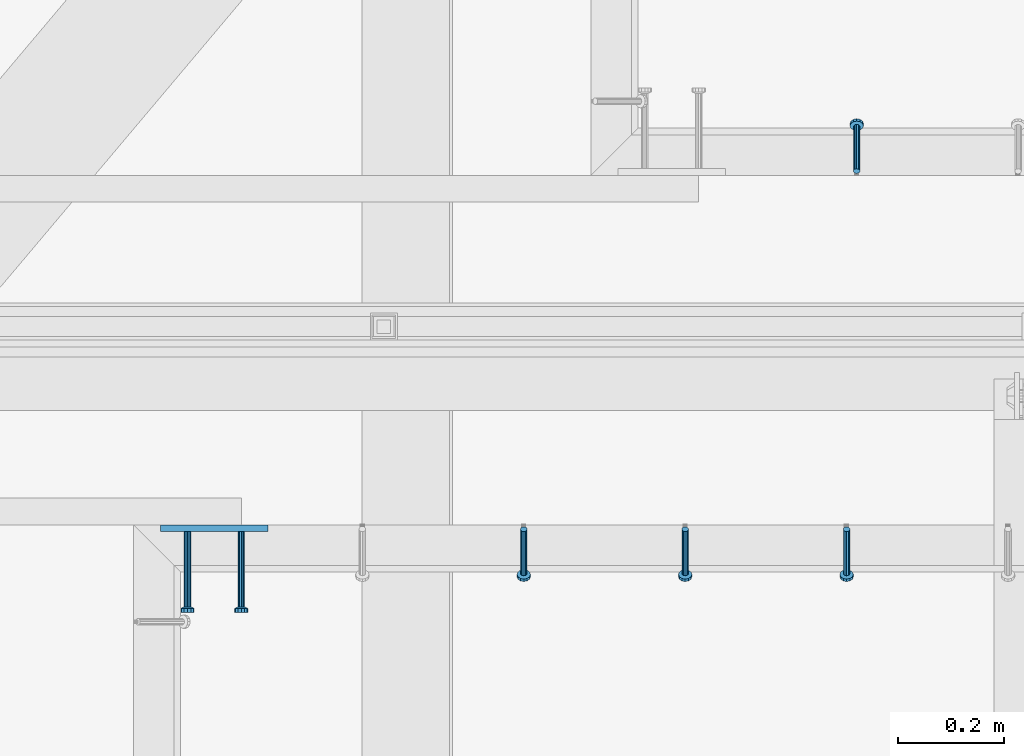
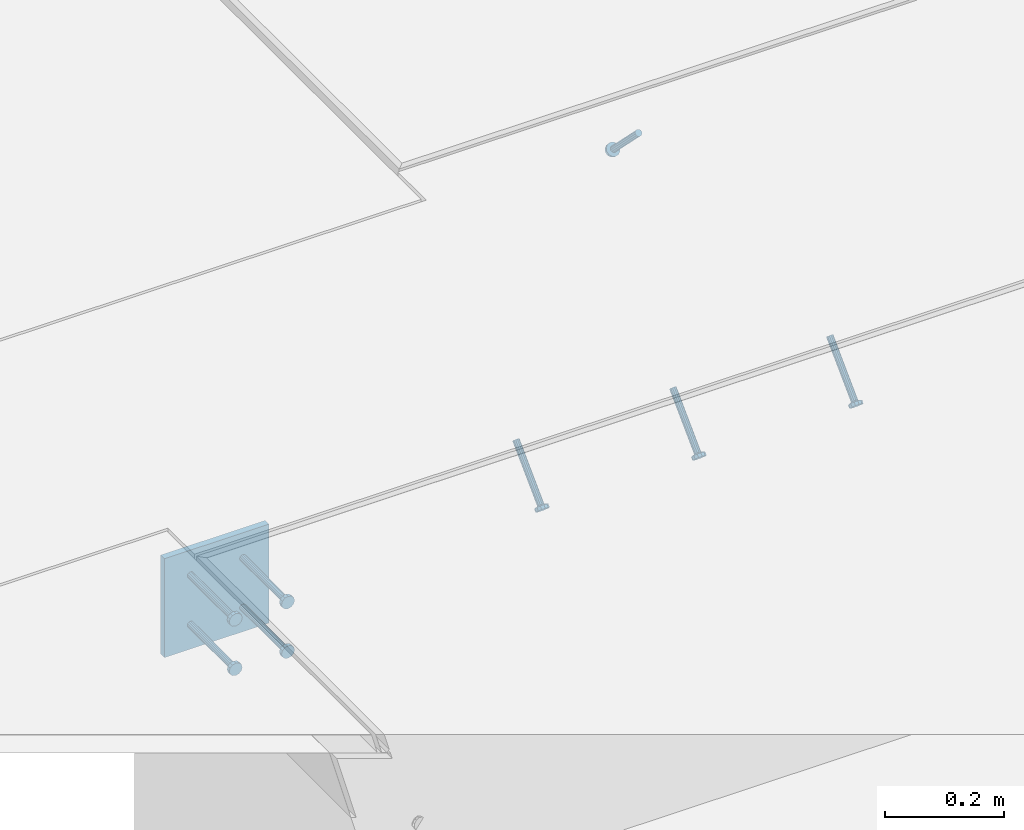
# One storey, part 2123 of 3843: 5 beams, 4 members, 3 elements without a shape of their own.
"""IFC2X3 building model written with IfcOpenShell, lengths in millimetres."""

from ifc_helpers import new_model, si_unit, frame, origin_with_axes, place, context, subcontext, project, spatial, faceted_brep, material, type_object, element, aggregate, save


model = new_model("IFC2X3")

# Units and contexts
model_context = context("Model", 3, precision=1e-05, world=origin_with_axes())
body_context = subcontext(model_context, "Body", "Model", "MODEL_VIEW")
ifc_project = project(units=[si_unit("LENGTHUNIT", "METRE", prefix="MILLI"), si_unit("AREAUNIT", "SQUARE_METRE"), si_unit("VOLUMEUNIT", "CUBIC_METRE"), si_unit("MASSUNIT", "GRAM", prefix="KILO"), si_unit("TIMEUNIT", "SECOND"), si_unit("PLANEANGLEUNIT", "RADIAN"), si_unit("SOLIDANGLEUNIT", "STERADIAN"), si_unit("THERMODYNAMICTEMPERATUREUNIT", "DEGREE_CELSIUS"), si_unit("LUMINOUSINTENSITYUNIT", "LUMEN")], contexts=[model_context])

# Site, building, storey
site_placement = place(None, origin_with_axes())
site = spatial("IfcSite", under=ifc_project, at=site_placement, CompositionType="ELEMENT")
building_placement = place(site_placement, origin_with_axes())
building = spatial("IfcBuilding", under=site, at=building_placement, Name="Undefined", CompositionType="ELEMENT")
storey_placement = place(building_placement, origin_with_axes())
storey = spatial("IfcBuildingStorey", under=building, at=storey_placement, Name="Undefined", CompositionType="ELEMENT", Elevation=0.0)

# Assembly, member
assembly_1_placement = place(storey_placement, origin_with_axes())
assembly_1 = element("IfcElementAssembly", 1, at=assembly_1_placement, inside=storey, Name="EMBED_ANGLE", AssemblyPlace="NOTDEFINED", PredefinedType="RIGID_FRAME")
ifc_material_1 = material(Name="STEEL/A108")
member_type = type_object("IfcMemberType", PredefinedType="NOTDEFINED")
member_1_placement = place(assembly_1_placement, frame((53309.0118945312, 28836.9375, 30446.6625), z_axis=(-1.0, 0.0, 0.0), x_axis=(5.70000238222118e-08, 0.707106781186546, -0.707106781186546)))
member_1 = element("IfcMember", 2, at=member_1_placement, type_object=member_type, material=ifc_material_1, Name="HEADED STUD ANCHOR", context=body_context, shape_type="Brep", body=[
    faceted_brep([(7.27595761418343e-12, -3.18000006675175, 5.5), (0.0, -5.49999999998363, 3.1800000667572), (118.110000000976, -5.49999999999091, 3.1800000667572), (118.110000000983, -3.18000006675175, 5.5), (0.0, -6.3499999046162, 0.0), (118.110000000968, -6.34999990461256, 0.0), (0.0, -5.49999999998363, -3.1800000667572), (118.110000000976, -5.49999999999091, -3.1800000667572), (7.27595761418343e-12, -3.18000006675175, -5.5), (118.110000000983, -3.18000006675175, -5.5), (7.27595761418343e-12, -1.81898940354586e-12, -6.34999990463257), (118.110000000968, -1.81898940354586e-12, -6.34999990463257), (0.0, 3.18000006675175, -5.5), (118.110000000968, 3.18000006674811, -5.5), (7.27595761418343e-12, 5.49999999998363, -3.1800000667572), (118.110000000983, 5.49999999998363, -3.1800000667572), (7.27595761418343e-12, 6.3499999046162, 0.0), (118.110000000976, 6.34999990461256, 0.0), (7.27595761418343e-12, 5.49999999998363, 3.1800000667572), (118.110000000983, 5.49999999998363, 3.1800000667572), (0.0, 3.18000006675175, 5.5), (118.110000000968, 3.18000006674811, 5.5), (7.27595761418343e-12, -1.81898940354586e-12, 6.34999990463257), (118.110000000968, -1.81898940354586e-12, 6.34999990463257), (120.650000000991, -10.9899997710909, 6.34999990463257), (120.650000000998, -6.34000015257152, 10.9899997711182), (120.650000000991, -12.6999998092379, 0.0), (120.650000000991, -10.9899997710909, -6.34999990463257), (120.650000000998, -6.34000015257152, -10.9899997711182), (120.650000000991, -1.81898940354586e-12, -12.6899995803833), (120.650000000991, 6.34000015257152, -10.9899997711182), (120.650000000998, 10.9899997710909, -6.34999990463257), (120.650000000991, 12.6999998092342, 0.0), (120.650000000998, 10.9899997710909, 6.34999990463257), (120.650000000991, 6.34000015257152, 10.9899997711182), (120.650000000991, -1.81898940354586e-12, 12.6899995803833), (127.000000001048, -10.9899997710945, 6.34999990463257), (127.000000001048, -6.34000015257152, 10.9899997711182), (127.000000001048, -12.6999998092342, 0.0), (127.000000001048, -10.9899997710945, -6.34999990463257), (127.000000001048, -6.34000015257152, -10.9899997711182), (127.000000001048, 1.81898940354586e-12, -12.6899995803833), (127.000000001048, 6.34000015256788, -10.9899997711182), (127.000000001048, 10.9899997710909, -6.34999990463257), (127.000000001048, 12.6999998092379, 0.0), (127.000000001048, 10.9899997710909, 6.34999990463257), (127.000000001048, 6.34000015256788, 10.9899997711182), (127.000000001048, 1.81898940354586e-12, 12.6899995803833)], [[[0, 1, 2, 3]], [[1, 4, 5, 2]], [[4, 6, 7, 5]], [[6, 8, 9, 7]], [[8, 10, 11, 9]], [[10, 12, 13, 11]], [[12, 14, 15, 13]], [[14, 16, 17, 15]], [[16, 18, 19, 17]], [[18, 20, 21, 19]], [[20, 22, 23, 21]], [[22, 0, 3, 23]], [[22, 20, 18, 16, 14, 12, 10, 8, 6, 4, 1, 0]], [[3, 2, 24, 25]], [[2, 5, 26, 24]], [[5, 7, 27, 26]], [[7, 9, 28, 27]], [[9, 11, 29, 28]], [[11, 13, 30, 29]], [[13, 15, 31, 30]], [[15, 17, 32, 31]], [[17, 19, 33, 32]], [[19, 21, 34, 33]], [[21, 23, 35, 34]], [[23, 3, 25, 35]], [[25, 24, 36, 37]], [[24, 26, 38, 36]], [[26, 27, 39, 38]], [[27, 28, 40, 39]], [[28, 29, 41, 40]], [[29, 30, 42, 41]], [[30, 31, 43, 42]], [[31, 32, 44, 43]], [[32, 33, 45, 44]], [[33, 34, 46, 45]], [[34, 35, 47, 46]], [[35, 25, 37, 47]], [[38, 39, 40, 41, 42, 43, 44, 45, 46, 47, 37, 36]]]),
])
aggregate(assembly_1, [member_1])

# Assembly, members
assembly_2_placement = place(storey_placement, origin_with_axes())
assembly_2 = element("IfcElementAssembly", 3, at=assembly_2_placement, inside=storey, Name="EMBED_ANGLE", AssemblyPlace="NOTDEFINED", PredefinedType="RIGID_FRAME")
member_2_placement = place(assembly_2_placement, frame((53289.9623417968, 28160.6624984764, 30446.6625), z_axis=(-1.0, 0.0, 0.0), x_axis=(0.0, -0.707106781186548, -0.707106781186548)))
member_2 = element("IfcMember", 4, at=member_2_placement, type_object=member_type, material=ifc_material_1, Name="HEADED STUD ANCHOR", context=body_context, shape_type="Brep", body=[
    faceted_brep([(7.27595761418343e-12, -3.18000006675175, 5.5), (0.0, -5.49999999998363, 3.1800000667572), (118.110000000976, -5.49999999999091, 3.1800000667572), (118.110000000983, -3.18000006675175, 5.5), (0.0, -6.3499999046162, 0.0), (118.110000000968, -6.34999990461256, 0.0), (0.0, -5.49999999998363, -3.1800000667572), (118.110000000976, -5.49999999999091, -3.1800000667572), (7.27595761418343e-12, -3.18000006675175, -5.5), (118.110000000983, -3.18000006675175, -5.5), (7.27595761418343e-12, -1.81898940354586e-12, -6.34999990463257), (118.110000000968, -1.81898940354586e-12, -6.34999990463257), (0.0, 3.18000006675175, -5.5), (118.110000000968, 3.18000006674811, -5.5), (7.27595761418343e-12, 5.49999999998363, -3.1800000667572), (118.110000000983, 5.49999999998363, -3.1800000667572), (7.27595761418343e-12, 6.3499999046162, 0.0), (118.110000000976, 6.34999990461256, 0.0), (7.27595761418343e-12, 5.49999999998363, 3.1800000667572), (118.110000000983, 5.49999999998363, 3.1800000667572), (0.0, 3.18000006675175, 5.5), (118.110000000968, 3.18000006674811, 5.5), (7.27595761418343e-12, -1.81898940354586e-12, 6.34999990463257), (118.110000000968, -1.81898940354586e-12, 6.34999990463257), (120.650000000991, -10.9899997710909, 6.34999990463257), (120.650000000998, -6.34000015257152, 10.9899997711182), (120.650000000991, -12.6999998092379, 0.0), (120.650000000991, -10.9899997710909, -6.34999990463257), (120.650000000998, -6.34000015257152, -10.9899997711182), (120.650000000991, -1.81898940354586e-12, -12.6899995803833), (120.650000000991, 6.34000015257152, -10.9899997711182), (120.650000000998, 10.9899997710909, -6.34999990463257), (120.650000000991, 12.6999998092342, 0.0), (120.650000000998, 10.9899997710909, 6.34999990463257), (120.650000000991, 6.34000015257152, 10.9899997711182), (120.650000000991, -1.81898940354586e-12, 12.6899995803833), (127.000000001048, -10.9899997710945, 6.34999990463257), (127.000000001048, -6.34000015257152, 10.9899997711182), (127.000000001048, -12.6999998092342, 0.0), (127.000000001048, -10.9899997710945, -6.34999990463257), (127.000000001048, -6.34000015257152, -10.9899997711182), (127.000000001048, 1.81898940354586e-12, -12.6899995803833), (127.000000001048, 6.34000015256788, -10.9899997711182), (127.000000001048, 10.9899997710909, -6.34999990463257), (127.000000001048, 12.6999998092379, 0.0), (127.000000001048, 10.9899997710909, 6.34999990463257), (127.000000001048, 6.34000015256788, 10.9899997711182), (127.000000001048, 1.81898940354586e-12, 12.6899995803833)], [[[0, 1, 2, 3]], [[1, 4, 5, 2]], [[4, 6, 7, 5]], [[6, 8, 9, 7]], [[8, 10, 11, 9]], [[10, 12, 13, 11]], [[12, 14, 15, 13]], [[14, 16, 17, 15]], [[16, 18, 19, 17]], [[18, 20, 21, 19]], [[20, 22, 23, 21]], [[22, 0, 3, 23]], [[22, 20, 18, 16, 14, 12, 10, 8, 6, 4, 1, 0]], [[3, 2, 24, 25]], [[2, 5, 26, 24]], [[5, 7, 27, 26]], [[7, 9, 28, 27]], [[9, 11, 29, 28]], [[11, 13, 30, 29]], [[13, 15, 31, 30]], [[15, 17, 32, 31]], [[17, 19, 33, 32]], [[19, 21, 34, 33]], [[21, 23, 35, 34]], [[23, 3, 25, 35]], [[25, 24, 36, 37]], [[24, 26, 38, 36]], [[26, 27, 39, 38]], [[27, 28, 40, 39]], [[28, 29, 41, 40]], [[29, 30, 42, 41]], [[30, 31, 43, 42]], [[31, 32, 44, 43]], [[32, 33, 45, 44]], [[33, 34, 46, 45]], [[34, 35, 47, 46]], [[35, 25, 37, 47]], [[38, 39, 40, 41, 42, 43, 44, 45, 46, 47, 37, 36]]]),
])
member_3_placement = place(assembly_2_placement, frame((52985.1623417968, 28160.6624984764, 30446.6625), z_axis=(-1.0, 0.0, 0.0), x_axis=(0.0, -0.707106781186548, -0.707106781186548)))
member_3 = element("IfcMember", 5, at=member_3_placement, type_object=member_type, material=ifc_material_1, Name="HEADED STUD ANCHOR", context=body_context, shape_type="Brep", body=[
    faceted_brep([(7.27595761418343e-12, -3.18000006675175, 5.5), (0.0, -5.49999999998363, 3.1800000667572), (118.110000000976, -5.49999999999091, 3.1800000667572), (118.110000000983, -3.18000006675175, 5.5), (0.0, -6.3499999046162, 0.0), (118.110000000968, -6.34999990461256, 0.0), (0.0, -5.49999999998363, -3.1800000667572), (118.110000000976, -5.49999999999091, -3.1800000667572), (7.27595761418343e-12, -3.18000006675175, -5.5), (118.110000000983, -3.18000006675175, -5.5), (7.27595761418343e-12, -1.81898940354586e-12, -6.34999990463257), (118.110000000968, -1.81898940354586e-12, -6.34999990463257), (0.0, 3.18000006675175, -5.5), (118.110000000968, 3.18000006674811, -5.5), (7.27595761418343e-12, 5.49999999998363, -3.1800000667572), (118.110000000983, 5.49999999998363, -3.1800000667572), (7.27595761418343e-12, 6.3499999046162, 0.0), (118.110000000976, 6.34999990461256, 0.0), (7.27595761418343e-12, 5.49999999998363, 3.1800000667572), (118.110000000983, 5.49999999998363, 3.1800000667572), (0.0, 3.18000006675175, 5.5), (118.110000000968, 3.18000006674811, 5.5), (7.27595761418343e-12, -1.81898940354586e-12, 6.34999990463257), (118.110000000968, -1.81898940354586e-12, 6.34999990463257), (120.650000000991, -10.9899997710909, 6.34999990463257), (120.650000000998, -6.34000015257152, 10.9899997711182), (120.650000000991, -12.6999998092379, 0.0), (120.650000000991, -10.9899997710909, -6.34999990463257), (120.650000000998, -6.34000015257152, -10.9899997711182), (120.650000000991, -1.81898940354586e-12, -12.6899995803833), (120.650000000991, 6.34000015257152, -10.9899997711182), (120.650000000998, 10.9899997710909, -6.34999990463257), (120.650000000991, 12.6999998092342, 0.0), (120.650000000998, 10.9899997710909, 6.34999990463257), (120.650000000991, 6.34000015257152, 10.9899997711182), (120.650000000991, -1.81898940354586e-12, 12.6899995803833), (127.000000001048, -10.9899997710945, 6.34999990463257), (127.000000001048, -6.34000015257152, 10.9899997711182), (127.000000001048, -12.6999998092342, 0.0), (127.000000001048, -10.9899997710945, -6.34999990463257), (127.000000001048, -6.34000015257152, -10.9899997711182), (127.000000001048, 1.81898940354586e-12, -12.6899995803833), (127.000000001048, 6.34000015256788, -10.9899997711182), (127.000000001048, 10.9899997710909, -6.34999990463257), (127.000000001048, 12.6999998092379, 0.0), (127.000000001048, 10.9899997710909, 6.34999990463257), (127.000000001048, 6.34000015256788, 10.9899997711182), (127.000000001048, 1.81898940354586e-12, 12.6899995803833)], [[[0, 1, 2, 3]], [[1, 4, 5, 2]], [[4, 6, 7, 5]], [[6, 8, 9, 7]], [[8, 10, 11, 9]], [[10, 12, 13, 11]], [[12, 14, 15, 13]], [[14, 16, 17, 15]], [[16, 18, 19, 17]], [[18, 20, 21, 19]], [[20, 22, 23, 21]], [[22, 0, 3, 23]], [[22, 20, 18, 16, 14, 12, 10, 8, 6, 4, 1, 0]], [[3, 2, 24, 25]], [[2, 5, 26, 24]], [[5, 7, 27, 26]], [[7, 9, 28, 27]], [[9, 11, 29, 28]], [[11, 13, 30, 29]], [[13, 15, 31, 30]], [[15, 17, 32, 31]], [[17, 19, 33, 32]], [[19, 21, 34, 33]], [[21, 23, 35, 34]], [[23, 3, 25, 35]], [[25, 24, 36, 37]], [[24, 26, 38, 36]], [[26, 27, 39, 38]], [[27, 28, 40, 39]], [[28, 29, 41, 40]], [[29, 30, 42, 41]], [[30, 31, 43, 42]], [[31, 32, 44, 43]], [[32, 33, 45, 44]], [[33, 34, 46, 45]], [[34, 35, 47, 46]], [[35, 25, 37, 47]], [[38, 39, 40, 41, 42, 43, 44, 45, 46, 47, 37, 36]]]),
])
member_4_placement = place(assembly_2_placement, frame((52680.3623417968, 28160.6624984764, 30446.6625), z_axis=(-1.0, 0.0, 0.0), x_axis=(0.0, -0.707106781186548, -0.707106781186548)))
member_4 = element("IfcMember", 6, at=member_4_placement, type_object=member_type, material=ifc_material_1, Name="HEADED STUD ANCHOR", context=body_context, shape_type="Brep", body=[
    faceted_brep([(7.27595761418343e-12, -3.18000006675175, 5.5), (0.0, -5.49999999998363, 3.1800000667572), (118.110000000976, -5.49999999999091, 3.1800000667572), (118.110000000983, -3.18000006675175, 5.5), (0.0, -6.3499999046162, 0.0), (118.110000000968, -6.34999990461256, 0.0), (0.0, -5.49999999998363, -3.1800000667572), (118.110000000976, -5.49999999999091, -3.1800000667572), (7.27595761418343e-12, -3.18000006675175, -5.5), (118.110000000983, -3.18000006675175, -5.5), (7.27595761418343e-12, -1.81898940354586e-12, -6.34999990463257), (118.110000000968, -1.81898940354586e-12, -6.34999990463257), (0.0, 3.18000006675175, -5.5), (118.110000000968, 3.18000006674811, -5.5), (7.27595761418343e-12, 5.49999999998363, -3.1800000667572), (118.110000000983, 5.49999999998363, -3.1800000667572), (7.27595761418343e-12, 6.3499999046162, 0.0), (118.110000000976, 6.34999990461256, 0.0), (7.27595761418343e-12, 5.49999999998363, 3.1800000667572), (118.110000000983, 5.49999999998363, 3.1800000667572), (0.0, 3.18000006675175, 5.5), (118.110000000968, 3.18000006674811, 5.5), (7.27595761418343e-12, -1.81898940354586e-12, 6.34999990463257), (118.110000000968, -1.81898940354586e-12, 6.34999990463257), (120.650000000991, -10.9899997710909, 6.34999990463257), (120.650000000998, -6.34000015257152, 10.9899997711182), (120.650000000991, -12.6999998092379, 0.0), (120.650000000991, -10.9899997710909, -6.34999990463257), (120.650000000998, -6.34000015257152, -10.9899997711182), (120.650000000991, -1.81898940354586e-12, -12.6899995803833), (120.650000000991, 6.34000015257152, -10.9899997711182), (120.650000000998, 10.9899997710909, -6.34999990463257), (120.650000000991, 12.6999998092342, 0.0), (120.650000000998, 10.9899997710909, 6.34999990463257), (120.650000000991, 6.34000015257152, 10.9899997711182), (120.650000000991, -1.81898940354586e-12, 12.6899995803833), (127.000000001048, -10.9899997710945, 6.34999990463257), (127.000000001048, -6.34000015257152, 10.9899997711182), (127.000000001048, -12.6999998092342, 0.0), (127.000000001048, -10.9899997710945, -6.34999990463257), (127.000000001048, -6.34000015257152, -10.9899997711182), (127.000000001048, 1.81898940354586e-12, -12.6899995803833), (127.000000001048, 6.34000015256788, -10.9899997711182), (127.000000001048, 10.9899997710909, -6.34999990463257), (127.000000001048, 12.6999998092379, 0.0), (127.000000001048, 10.9899997710909, 6.34999990463257), (127.000000001048, 6.34000015256788, 10.9899997711182), (127.000000001048, 1.81898940354586e-12, 12.6899995803833)], [[[0, 1, 2, 3]], [[1, 4, 5, 2]], [[4, 6, 7, 5]], [[6, 8, 9, 7]], [[8, 10, 11, 9]], [[10, 12, 13, 11]], [[12, 14, 15, 13]], [[14, 16, 17, 15]], [[16, 18, 19, 17]], [[18, 20, 21, 19]], [[20, 22, 23, 21]], [[22, 0, 3, 23]], [[22, 20, 18, 16, 14, 12, 10, 8, 6, 4, 1, 0]], [[3, 2, 24, 25]], [[2, 5, 26, 24]], [[5, 7, 27, 26]], [[7, 9, 28, 27]], [[9, 11, 29, 28]], [[11, 13, 30, 29]], [[13, 15, 31, 30]], [[15, 17, 32, 31]], [[17, 19, 33, 32]], [[19, 21, 34, 33]], [[21, 23, 35, 34]], [[23, 3, 25, 35]], [[25, 24, 36, 37]], [[24, 26, 38, 36]], [[26, 27, 39, 38]], [[27, 28, 40, 39]], [[28, 29, 41, 40]], [[29, 30, 42, 41]], [[30, 31, 43, 42]], [[31, 32, 44, 43]], [[32, 33, 45, 44]], [[33, 34, 46, 45]], [[34, 35, 47, 46]], [[35, 25, 37, 47]], [[38, 39, 40, 41, 42, 43, 44, 45, 46, 47, 37, 36]]]),
])
aggregate(assembly_2, [member_2, member_3, member_4])

# Assembly, beams
assembly_3_placement = place(storey_placement, origin_with_axes())
assembly_3 = element("IfcElementAssembly", 7, at=assembly_3_placement, inside=storey, Name="EMBED PLATE", AssemblyPlace="NOTDEFINED", PredefinedType="RIGID_FRAME")
ifc_material_2 = material(Name="STEEL/A36")
beam_type_1 = type_object("IfcBeamType", PredefinedType="NOTDEFINED")
beam_1_placement = place(assembly_3_placement, frame((52096.1623417968, 28162.25, 30445.075), z_axis=(-1.0, 0.0, 0.0), x_axis=(0.0, 0.0, -1.0)))
beam_1 = element("IfcBeam", 8, at=beam_1_placement, type_object=beam_type_1, material=ifc_material_2, Name="EMBED PLATE", context=body_context, shape_type="Brep", body=[
    faceted_brep([(1.74622982740402e-10, 6.35000000000582, -101.600000000195), (-1.67347025126219e-10, 6.35000000000582, 101.600000000151), (203.200000000001, 6.35000000000582, 101.599999999999), (203.200000000001, 6.35000000000582, -101.599999999999), (-1.67347025126219e-10, -6.35000000000582, 101.600000000151), (203.200000000001, -6.35000000000582, 101.599999999999), (1.74622982740402e-10, -6.35000000000582, -101.600000000195), (203.200000000001, -6.35000000000582, -101.599999999999)], [[[0, 1, 2, 3]], [[1, 4, 5, 2]], [[4, 6, 7, 5]], [[6, 0, 3, 7]], [[5, 7, 3, 2]], [[6, 4, 1, 0]]]),
])
beam_type_2 = type_object("IfcBeamType", PredefinedType="NOTDEFINED")
beam_2_placement = place(assembly_3_placement, frame((52146.9623417968, 28155.9, 30394.275), z_axis=(1.0, 0.0, 0.0), x_axis=(0.0, -1.0, 0.0)))
beam_2 = element("IfcBeam", 9, at=beam_2_placement, type_object=beam_type_2, material=ifc_material_1, Name="HEADED STUD ANCHOR", context=body_context, shape_type="Brep", body=[
    faceted_brep([(7.27595761418343e-12, -3.18000006675175, 5.5), (0.0, -5.49999999998363, 3.1800000667572), (141.731999999989, -5.5, 3.1800000667572), (141.731999999989, -3.1800000667572, 5.5), (0.0, -6.3499999046162, 0.0), (141.731999999989, -6.34999990463257, 0.0), (0.0, -5.49999999998363, -3.1800000667572), (141.731999999989, -5.5, -3.1800000667572), (7.27595761418343e-12, -3.18000006675175, -5.5), (141.731999999989, -3.1800000667572, -5.5), (7.27595761418343e-12, -1.81898940354586e-12, -6.34999990463257), (141.731999999989, 0.0, -6.34999990463257), (0.0, 3.18000006675175, -5.5), (141.731999999989, 3.1800000667572, -5.5), (7.27595761418343e-12, 5.49999999998363, -3.1800000667572), (141.731999999989, 5.5, -3.1800000667572), (7.27595761418343e-12, 6.3499999046162, 0.0), (141.731999999989, 6.34999990463257, 0.0), (7.27595761418343e-12, 5.49999999998363, 3.1800000667572), (141.731999999989, 5.5, 3.1800000667572), (0.0, 3.18000006675175, 5.5), (141.731999999989, 3.1800000667572, 5.5), (7.27595761418343e-12, -1.81898940354586e-12, 6.34999990463257), (141.731999999989, 0.0, 6.34999990463257), (144.779999999999, -10.9899997711182, 6.34999990463257), (144.779999999999, -6.34000015258789, 10.9899997711182), (144.779999999999, -12.6999998092651, 0.0), (144.779999999999, -10.9899997711182, -6.34999990463257), (144.779999999999, -6.34000015258789, -10.9899997711182), (144.779999999999, 0.0, -12.6899995803833), (144.779999999999, 6.34000015258789, -10.9899997711182), (144.779999999999, 10.9899997711182, -6.34999990463257), (144.779999999999, 12.6999998092651, 0.0), (144.779999999999, 10.9899997711182, 6.34999990463257), (144.779999999999, 6.34000015258789, 10.9899997711182), (144.779999999999, 0.0, 12.6899995803833), (152.399999999994, -10.9899997711182, 6.34999990463257), (152.399999999994, -6.34000015258789, 10.9899997711182), (152.399999999994, -12.6999998092651, 0.0), (152.399999999994, -10.9899997711182, -6.34999990463257), (152.399999999994, -6.34000015258789, -10.9899997711182), (152.399999999994, 0.0, -12.6899995803833), (152.399999999994, 6.34000015258789, -10.9899997711182), (152.399999999994, 10.9899997711182, -6.34999990463257), (152.399999999994, 12.6999998092651, 0.0), (152.399999999994, 10.9899997711182, 6.34999990463257), (152.399999999994, 6.34000015258789, 10.9899997711182), (152.399999999994, 0.0, 12.6899995803833)], [[[0, 1, 2, 3]], [[1, 4, 5, 2]], [[4, 6, 7, 5]], [[6, 8, 9, 7]], [[8, 10, 11, 9]], [[10, 12, 13, 11]], [[12, 14, 15, 13]], [[14, 16, 17, 15]], [[16, 18, 19, 17]], [[18, 20, 21, 19]], [[20, 22, 23, 21]], [[22, 0, 3, 23]], [[22, 20, 18, 16, 14, 12, 10, 8, 6, 4, 1, 0]], [[3, 2, 24, 25]], [[2, 5, 26, 24]], [[5, 7, 27, 26]], [[7, 9, 28, 27]], [[9, 11, 29, 28]], [[11, 13, 30, 29]], [[13, 15, 31, 30]], [[15, 17, 32, 31]], [[17, 19, 33, 32]], [[19, 21, 34, 33]], [[21, 23, 35, 34]], [[23, 3, 25, 35]], [[25, 24, 36, 37]], [[24, 26, 38, 36]], [[26, 27, 39, 38]], [[27, 28, 40, 39]], [[28, 29, 41, 40]], [[29, 30, 42, 41]], [[30, 31, 43, 42]], [[31, 32, 44, 43]], [[32, 33, 45, 44]], [[33, 34, 46, 45]], [[34, 35, 47, 46]], [[35, 25, 37, 47]], [[38, 39, 40, 41, 42, 43, 44, 45, 46, 47, 37, 36]]]),
])
beam_3_placement = place(assembly_3_placement, frame((52146.9623417968, 28155.9, 30292.675), z_axis=(1.0, 0.0, 0.0), x_axis=(0.0, -1.0, 0.0)))
beam_3 = element("IfcBeam", 10, at=beam_3_placement, type_object=beam_type_2, material=ifc_material_1, Name="HEADED STUD ANCHOR", context=body_context, shape_type="Brep", body=[
    faceted_brep([(7.27595761418343e-12, -3.18000006675175, 5.5), (0.0, -5.49999999998363, 3.1800000667572), (141.731999999989, -5.5, 3.1800000667572), (141.731999999989, -3.1800000667572, 5.5), (0.0, -6.3499999046162, 0.0), (141.731999999989, -6.34999990463257, 0.0), (0.0, -5.49999999998363, -3.1800000667572), (141.731999999989, -5.5, -3.1800000667572), (7.27595761418343e-12, -3.18000006675175, -5.5), (141.731999999989, -3.1800000667572, -5.5), (7.27595761418343e-12, -1.81898940354586e-12, -6.34999990463257), (141.731999999989, 0.0, -6.34999990463257), (0.0, 3.18000006675175, -5.5), (141.731999999989, 3.1800000667572, -5.5), (7.27595761418343e-12, 5.49999999998363, -3.1800000667572), (141.731999999989, 5.5, -3.1800000667572), (7.27595761418343e-12, 6.3499999046162, 0.0), (141.731999999989, 6.34999990463257, 0.0), (7.27595761418343e-12, 5.49999999998363, 3.1800000667572), (141.731999999989, 5.5, 3.1800000667572), (0.0, 3.18000006675175, 5.5), (141.731999999989, 3.1800000667572, 5.5), (7.27595761418343e-12, -1.81898940354586e-12, 6.34999990463257), (141.731999999989, 0.0, 6.34999990463257), (144.779999999999, -10.9899997711182, 6.34999990463257), (144.779999999999, -6.34000015258789, 10.9899997711182), (144.779999999999, -12.6999998092651, 0.0), (144.779999999999, -10.9899997711182, -6.34999990463257), (144.779999999999, -6.34000015258789, -10.9899997711182), (144.779999999999, 0.0, -12.6899995803833), (144.779999999999, 6.34000015258789, -10.9899997711182), (144.779999999999, 10.9899997711182, -6.34999990463257), (144.779999999999, 12.6999998092651, 0.0), (144.779999999999, 10.9899997711182, 6.34999990463257), (144.779999999999, 6.34000015258789, 10.9899997711182), (144.779999999999, 0.0, 12.6899995803833), (152.399999999994, -10.9899997711182, 6.34999990463257), (152.399999999994, -6.34000015258789, 10.9899997711182), (152.399999999994, -12.6999998092651, 0.0), (152.399999999994, -10.9899997711182, -6.34999990463257), (152.399999999994, -6.34000015258789, -10.9899997711182), (152.399999999994, 0.0, -12.6899995803833), (152.399999999994, 6.34000015258789, -10.9899997711182), (152.399999999994, 10.9899997711182, -6.34999990463257), (152.399999999994, 12.6999998092651, 0.0), (152.399999999994, 10.9899997711182, 6.34999990463257), (152.399999999994, 6.34000015258789, 10.9899997711182), (152.399999999994, 0.0, 12.6899995803833)], [[[0, 1, 2, 3]], [[1, 4, 5, 2]], [[4, 6, 7, 5]], [[6, 8, 9, 7]], [[8, 10, 11, 9]], [[10, 12, 13, 11]], [[12, 14, 15, 13]], [[14, 16, 17, 15]], [[16, 18, 19, 17]], [[18, 20, 21, 19]], [[20, 22, 23, 21]], [[22, 0, 3, 23]], [[22, 20, 18, 16, 14, 12, 10, 8, 6, 4, 1, 0]], [[3, 2, 24, 25]], [[2, 5, 26, 24]], [[5, 7, 27, 26]], [[7, 9, 28, 27]], [[9, 11, 29, 28]], [[11, 13, 30, 29]], [[13, 15, 31, 30]], [[15, 17, 32, 31]], [[17, 19, 33, 32]], [[19, 21, 34, 33]], [[21, 23, 35, 34]], [[23, 3, 25, 35]], [[25, 24, 36, 37]], [[24, 26, 38, 36]], [[26, 27, 39, 38]], [[27, 28, 40, 39]], [[28, 29, 41, 40]], [[29, 30, 42, 41]], [[30, 31, 43, 42]], [[31, 32, 44, 43]], [[32, 33, 45, 44]], [[33, 34, 46, 45]], [[34, 35, 47, 46]], [[35, 25, 37, 47]], [[38, 39, 40, 41, 42, 43, 44, 45, 46, 47, 37, 36]]]),
])
beam_4_placement = place(assembly_3_placement, frame((52045.3623417968, 28155.9, 30394.275), z_axis=(1.0, 0.0, 0.0), x_axis=(0.0, -1.0, 0.0)))
beam_4 = element("IfcBeam", 11, at=beam_4_placement, type_object=beam_type_2, material=ifc_material_1, Name="HEADED STUD ANCHOR", context=body_context, shape_type="Brep", body=[
    faceted_brep([(7.27595761418343e-12, -3.18000006675175, 5.5), (0.0, -5.49999999998363, 3.1800000667572), (141.731999999989, -5.5, 3.1800000667572), (141.731999999989, -3.1800000667572, 5.5), (0.0, -6.3499999046162, 0.0), (141.731999999989, -6.34999990463257, 0.0), (0.0, -5.49999999998363, -3.1800000667572), (141.731999999989, -5.5, -3.1800000667572), (7.27595761418343e-12, -3.18000006675175, -5.5), (141.731999999989, -3.1800000667572, -5.5), (7.27595761418343e-12, -1.81898940354586e-12, -6.34999990463257), (141.731999999989, 0.0, -6.34999990463257), (0.0, 3.18000006675175, -5.5), (141.731999999989, 3.1800000667572, -5.5), (7.27595761418343e-12, 5.49999999998363, -3.1800000667572), (141.731999999989, 5.5, -3.1800000667572), (7.27595761418343e-12, 6.3499999046162, 0.0), (141.731999999989, 6.34999990463257, 0.0), (7.27595761418343e-12, 5.49999999998363, 3.1800000667572), (141.731999999989, 5.5, 3.1800000667572), (0.0, 3.18000006675175, 5.5), (141.731999999989, 3.1800000667572, 5.5), (7.27595761418343e-12, -1.81898940354586e-12, 6.34999990463257), (141.731999999989, 0.0, 6.34999990463257), (144.779999999999, -10.9899997711182, 6.34999990463257), (144.779999999999, -6.34000015258789, 10.9899997711182), (144.779999999999, -12.6999998092651, 0.0), (144.779999999999, -10.9899997711182, -6.34999990463257), (144.779999999999, -6.34000015258789, -10.9899997711182), (144.779999999999, 0.0, -12.6899995803833), (144.779999999999, 6.34000015258789, -10.9899997711182), (144.779999999999, 10.9899997711182, -6.34999990463257), (144.779999999999, 12.6999998092651, 0.0), (144.779999999999, 10.9899997711182, 6.34999990463257), (144.779999999999, 6.34000015258789, 10.9899997711182), (144.779999999999, 0.0, 12.6899995803833), (152.399999999994, -10.9899997711182, 6.34999990463257), (152.399999999994, -6.34000015258789, 10.9899997711182), (152.399999999994, -12.6999998092651, 0.0), (152.399999999994, -10.9899997711182, -6.34999990463257), (152.399999999994, -6.34000015258789, -10.9899997711182), (152.399999999994, 0.0, -12.6899995803833), (152.399999999994, 6.34000015258789, -10.9899997711182), (152.399999999994, 10.9899997711182, -6.34999990463257), (152.399999999994, 12.6999998092651, 0.0), (152.399999999994, 10.9899997711182, 6.34999990463257), (152.399999999994, 6.34000015258789, 10.9899997711182), (152.399999999994, 0.0, 12.6899995803833)], [[[0, 1, 2, 3]], [[1, 4, 5, 2]], [[4, 6, 7, 5]], [[6, 8, 9, 7]], [[8, 10, 11, 9]], [[10, 12, 13, 11]], [[12, 14, 15, 13]], [[14, 16, 17, 15]], [[16, 18, 19, 17]], [[18, 20, 21, 19]], [[20, 22, 23, 21]], [[22, 0, 3, 23]], [[22, 20, 18, 16, 14, 12, 10, 8, 6, 4, 1, 0]], [[3, 2, 24, 25]], [[2, 5, 26, 24]], [[5, 7, 27, 26]], [[7, 9, 28, 27]], [[9, 11, 29, 28]], [[11, 13, 30, 29]], [[13, 15, 31, 30]], [[15, 17, 32, 31]], [[17, 19, 33, 32]], [[19, 21, 34, 33]], [[21, 23, 35, 34]], [[23, 3, 25, 35]], [[25, 24, 36, 37]], [[24, 26, 38, 36]], [[26, 27, 39, 38]], [[27, 28, 40, 39]], [[28, 29, 41, 40]], [[29, 30, 42, 41]], [[30, 31, 43, 42]], [[31, 32, 44, 43]], [[32, 33, 45, 44]], [[33, 34, 46, 45]], [[34, 35, 47, 46]], [[35, 25, 37, 47]], [[38, 39, 40, 41, 42, 43, 44, 45, 46, 47, 37, 36]]]),
])
beam_5_placement = place(assembly_3_placement, frame((52045.3623417968, 28155.9, 30292.675), z_axis=(1.0, 0.0, 0.0), x_axis=(0.0, -1.0, 0.0)))
beam_5 = element("IfcBeam", 12, at=beam_5_placement, type_object=beam_type_2, material=ifc_material_1, Name="HEADED STUD ANCHOR", context=body_context, shape_type="Brep", body=[
    faceted_brep([(7.27595761418343e-12, -3.18000006675175, 5.5), (0.0, -5.49999999998363, 3.1800000667572), (141.731999999989, -5.5, 3.1800000667572), (141.731999999989, -3.1800000667572, 5.5), (0.0, -6.3499999046162, 0.0), (141.731999999989, -6.34999990463257, 0.0), (0.0, -5.49999999998363, -3.1800000667572), (141.731999999989, -5.5, -3.1800000667572), (7.27595761418343e-12, -3.18000006675175, -5.5), (141.731999999989, -3.1800000667572, -5.5), (7.27595761418343e-12, -1.81898940354586e-12, -6.34999990463257), (141.731999999989, 0.0, -6.34999990463257), (0.0, 3.18000006675175, -5.5), (141.731999999989, 3.1800000667572, -5.5), (7.27595761418343e-12, 5.49999999998363, -3.1800000667572), (141.731999999989, 5.5, -3.1800000667572), (7.27595761418343e-12, 6.3499999046162, 0.0), (141.731999999989, 6.34999990463257, 0.0), (7.27595761418343e-12, 5.49999999998363, 3.1800000667572), (141.731999999989, 5.5, 3.1800000667572), (0.0, 3.18000006675175, 5.5), (141.731999999989, 3.1800000667572, 5.5), (7.27595761418343e-12, -1.81898940354586e-12, 6.34999990463257), (141.731999999989, 0.0, 6.34999990463257), (144.779999999999, -10.9899997711182, 6.34999990463257), (144.779999999999, -6.34000015258789, 10.9899997711182), (144.779999999999, -12.6999998092651, 0.0), (144.779999999999, -10.9899997711182, -6.34999990463257), (144.779999999999, -6.34000015258789, -10.9899997711182), (144.779999999999, 0.0, -12.6899995803833), (144.779999999999, 6.34000015258789, -10.9899997711182), (144.779999999999, 10.9899997711182, -6.34999990463257), (144.779999999999, 12.6999998092651, 0.0), (144.779999999999, 10.9899997711182, 6.34999990463257), (144.779999999999, 6.34000015258789, 10.9899997711182), (144.779999999999, 0.0, 12.6899995803833), (152.399999999994, -10.9899997711182, 6.34999990463257), (152.399999999994, -6.34000015258789, 10.9899997711182), (152.399999999994, -12.6999998092651, 0.0), (152.399999999994, -10.9899997711182, -6.34999990463257), (152.399999999994, -6.34000015258789, -10.9899997711182), (152.399999999994, 0.0, -12.6899995803833), (152.399999999994, 6.34000015258789, -10.9899997711182), (152.399999999994, 10.9899997711182, -6.34999990463257), (152.399999999994, 12.6999998092651, 0.0), (152.399999999994, 10.9899997711182, 6.34999990463257), (152.399999999994, 6.34000015258789, 10.9899997711182), (152.399999999994, 0.0, 12.6899995803833)], [[[0, 1, 2, 3]], [[1, 4, 5, 2]], [[4, 6, 7, 5]], [[6, 8, 9, 7]], [[8, 10, 11, 9]], [[10, 12, 13, 11]], [[12, 14, 15, 13]], [[14, 16, 17, 15]], [[16, 18, 19, 17]], [[18, 20, 21, 19]], [[20, 22, 23, 21]], [[22, 0, 3, 23]], [[22, 20, 18, 16, 14, 12, 10, 8, 6, 4, 1, 0]], [[3, 2, 24, 25]], [[2, 5, 26, 24]], [[5, 7, 27, 26]], [[7, 9, 28, 27]], [[9, 11, 29, 28]], [[11, 13, 30, 29]], [[13, 15, 31, 30]], [[15, 17, 32, 31]], [[17, 19, 33, 32]], [[19, 21, 34, 33]], [[21, 23, 35, 34]], [[23, 3, 25, 35]], [[25, 24, 36, 37]], [[24, 26, 38, 36]], [[26, 27, 39, 38]], [[27, 28, 40, 39]], [[28, 29, 41, 40]], [[29, 30, 42, 41]], [[30, 31, 43, 42]], [[31, 32, 44, 43]], [[32, 33, 45, 44]], [[33, 34, 46, 45]], [[34, 35, 47, 46]], [[35, 25, 37, 47]], [[38, 39, 40, 41, 42, 43, 44, 45, 46, 47, 37, 36]]]),
])
aggregate(assembly_3, [beam_2, beam_3, beam_4, beam_5, beam_1])

save(model, "model.ifc")
